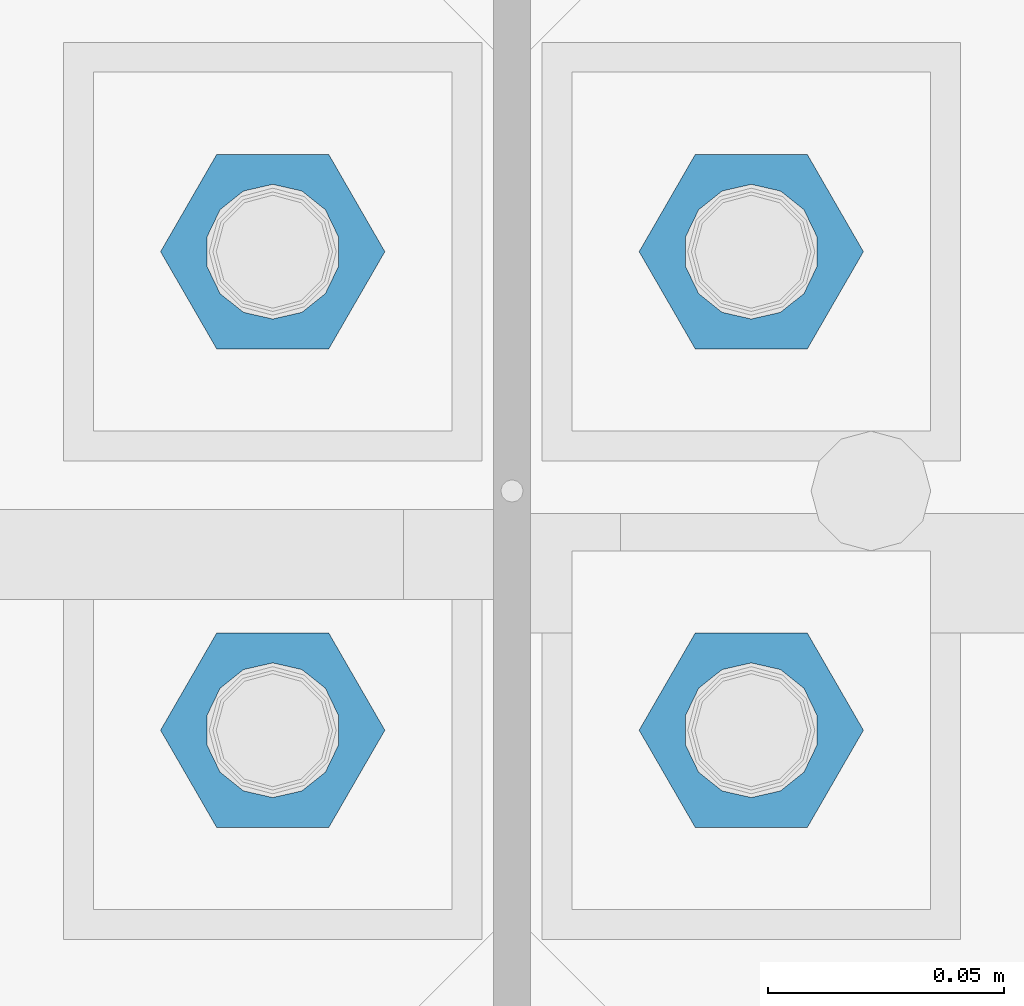
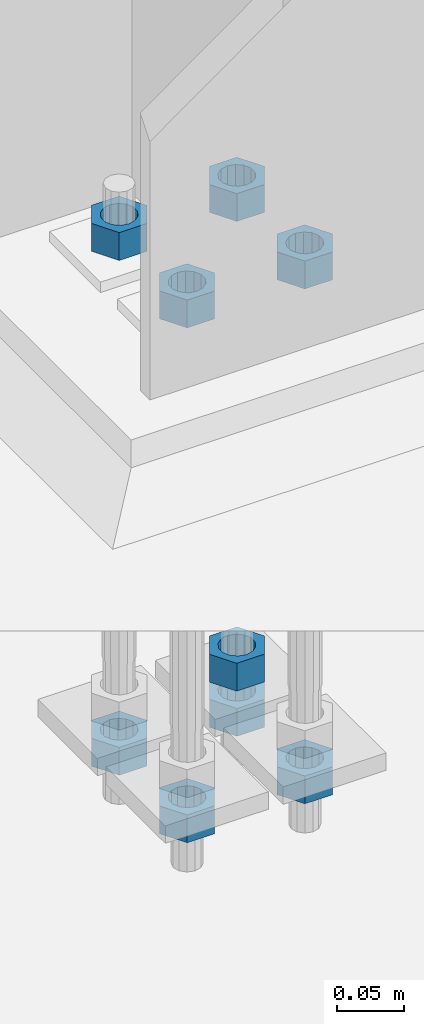
# One storey, part 1689 of 3843: 9 columns, 1 element without a shape of its own.
"""IFC2X3 building model written with IfcOpenShell, lengths in millimetres."""

from ifc_helpers import new_model, si_unit, frame, origin_with_axes, place, context, subcontext, project, spatial, faceted_brep, material, type_object, element, aggregate, save


model = new_model("IFC2X3")

# Units and contexts
model_context = context("Model", 3, precision=1e-05, world=origin_with_axes())
body_context = subcontext(model_context, "Body", "Model", "MODEL_VIEW")
ifc_project = project(units=[si_unit("LENGTHUNIT", "METRE", prefix="MILLI"), si_unit("AREAUNIT", "SQUARE_METRE"), si_unit("VOLUMEUNIT", "CUBIC_METRE"), si_unit("MASSUNIT", "GRAM", prefix="KILO"), si_unit("TIMEUNIT", "SECOND"), si_unit("PLANEANGLEUNIT", "RADIAN"), si_unit("SOLIDANGLEUNIT", "STERADIAN"), si_unit("THERMODYNAMICTEMPERATUREUNIT", "DEGREE_CELSIUS"), si_unit("LUMINOUSINTENSITYUNIT", "LUMEN")], contexts=[model_context])

# Site, building, storey
site_placement = place(None, origin_with_axes())
site = spatial("IfcSite", under=ifc_project, at=site_placement, CompositionType="ELEMENT")
building_placement = place(site_placement, origin_with_axes())
building = spatial("IfcBuilding", under=site, at=building_placement, Name="Undefined", CompositionType="ELEMENT")
storey_placement = place(building_placement, origin_with_axes())
storey = spatial("IfcBuildingStorey", under=building, at=storey_placement, Name="Undefined", CompositionType="ELEMENT", Elevation=0.0)

# Assembly, columns
assembly_placement = place(storey_placement, origin_with_axes())
assembly = element("IfcElementAssembly", 1, at=assembly_placement, inside=storey, Name="TEMPLATE", AssemblyPlace="NOTDEFINED", PredefinedType="RIGID_FRAME")
ifc_material = material(Name="STEEL/A36")
column_type = type_object("IfcColumnType", Name="1_HEAVY_HEX_NUT", PredefinedType="NOTDEFINED")
column_1_placement = place(assembly_placement, frame((7670.8, 104609.9, 29692.6), z_axis=(0.0, 1.0, 0.0), x_axis=(0.0, 0.0, -1.0)))
column_1 = element("IfcColumn", 2, at=column_1_placement, type_object=column_type, material=ifc_material, Name="NUT", ObjectType="1_HEAVY_HEX_NUT", context=body_context, shape_type="Brep", body=[
    faceted_brep([(0.0, -23.8099994659424, 0.0), (0.0, -11.9099998474121, -20.6200008392334), (25.3999999999978, -11.9099998474121, -20.6200008392334), (25.3999999999978, -23.8099994659424, 0.0), (0.0, 11.9099998474121, -20.6200008392334), (25.3999999999978, 11.9099998474121, -20.6200008392334), (0.0, 23.8099994659424, 0.0), (25.3999999999978, 23.8099994659424, 0.0), (0.0, 11.9099998474121, 20.6200008392334), (25.3999999999978, 11.9099998474121, 20.6200008392334), (0.0, -11.9099998474121, 20.6200008392334), (25.3999999999978, -11.9099998474121, 20.6200008392334), (0.0, 0.0, 14.289999961853), (0.0, 6.20019861543551, 12.8748450879575), (25.3999999999978, 6.20019861543551, 12.8748450879575), (25.3999999999978, 0.0, 14.289999961853), (0.0, 11.1723718546418, 8.90966924477834), (25.3999999999978, 11.1723718546418, 8.90966924477834), (0.0, 13.9317198278877, 3.17982413774735), (25.3999999999978, 13.9317198278877, 3.17982413774735), (0.0, 13.9317198278877, -3.17982413774735), (25.3999999999978, 13.9317198278877, -3.17982413774735), (0.0, 11.1723718546418, -8.90966924477834), (25.3999999999978, 11.1723718546418, -8.90966924477834), (0.0, 6.20019861543551, -12.8748450879575), (25.3999999999978, 6.20019861543551, -12.8748450879575), (0.0, 0.0, -14.289999961853), (25.3999999999978, 0.0, -14.289999961853), (0.0, -6.20019861543551, -12.8748450879575), (25.3999999999978, -6.20019861543551, -12.8748450879575), (0.0, -11.1723718546418, -8.90966924477834), (25.3999999999978, -11.1723718546418, -8.90966924477834), (0.0, -13.9317198278877, -3.17982413774735), (25.3999999999978, -13.9317198278877, -3.17982413774735), (0.0, -13.9317198278877, 3.17982413774735), (25.3999999999978, -13.9317198278877, 3.17982413774735), (0.0, -11.1723718546418, 8.90966924477834), (25.3999999999978, -11.1723718546418, 8.90966924477834), (0.0, -6.20019861543551, 12.8748450879575), (25.3999999999978, -6.20019861543551, 12.8748450879575)], [[[0, 1, 2, 3]], [[1, 4, 5, 2]], [[4, 6, 7, 5]], [[6, 8, 9, 7]], [[8, 10, 11, 9]], [[10, 0, 3, 11]], [[12, 13, 14, 15]], [[13, 16, 17, 14]], [[16, 18, 19, 17]], [[18, 20, 21, 19]], [[20, 22, 23, 21]], [[22, 24, 25, 23]], [[24, 26, 27, 25]], [[26, 28, 29, 27]], [[28, 30, 31, 29]], [[30, 32, 33, 31]], [[32, 34, 35, 33]], [[34, 36, 37, 35]], [[36, 38, 39, 37]], [[38, 12, 15, 39]], [[5, 7, 9, 11, 3, 2], [17, 19, 21, 23, 25, 27, 29, 31, 33, 35, 37, 39, 15, 14]], [[10, 8, 6, 4, 1, 0], [38, 36, 34, 32, 30, 28, 26, 24, 22, 20, 18, 16, 13, 12]]]),
])
column_2_placement = place(assembly_placement, frame((7569.2, 104508.3, 30121.225), z_axis=(0.0, -1.0, 0.0), x_axis=(0.0, 0.0, -1.0)))
column_2 = element("IfcColumn", 3, at=column_2_placement, type_object=column_type, material=ifc_material, Name="NUT", ObjectType="1_HEAVY_HEX_NUT", context=body_context, shape_type="Brep", body=[
    faceted_brep([(0.0, -23.8099994659424, 0.0), (0.0, -11.9099998474121, -20.6200008392334), (25.3999999999978, -11.9099998474121, -20.6200008392334), (25.3999999999978, -23.8099994659424, 0.0), (0.0, 11.9099998474121, -20.6200008392334), (25.3999999999978, 11.9099998474121, -20.6200008392334), (0.0, 23.8099994659424, 0.0), (25.3999999999978, 23.8099994659424, 0.0), (0.0, 11.9099998474121, 20.6200008392334), (25.3999999999978, 11.9099998474121, 20.6200008392334), (0.0, -11.9099998474121, 20.6200008392334), (25.3999999999978, -11.9099998474121, 20.6200008392334), (0.0, 0.0, 14.289999961853), (0.0, 6.20019861543551, 12.8748450879575), (25.3999999999978, 6.20019861543551, 12.8748450879575), (25.3999999999978, 0.0, 14.289999961853), (0.0, 11.1723718546418, 8.90966924477834), (25.3999999999978, 11.1723718546418, 8.90966924477834), (0.0, 13.9317198278877, 3.17982413774735), (25.3999999999978, 13.9317198278877, 3.17982413774735), (0.0, 13.9317198278877, -3.17982413774735), (25.3999999999978, 13.9317198278877, -3.17982413774735), (0.0, 11.1723718546418, -8.90966924477834), (25.3999999999978, 11.1723718546418, -8.90966924477834), (0.0, 6.20019861543551, -12.8748450879575), (25.3999999999978, 6.20019861543551, -12.8748450879575), (0.0, 0.0, -14.289999961853), (25.3999999999978, 0.0, -14.289999961853), (0.0, -6.20019861543551, -12.8748450879575), (25.3999999999978, -6.20019861543551, -12.8748450879575), (0.0, -11.1723718546418, -8.90966924477834), (25.3999999999978, -11.1723718546418, -8.90966924477834), (0.0, -13.9317198278877, -3.17982413774735), (25.3999999999978, -13.9317198278877, -3.17982413774735), (0.0, -13.9317198278877, 3.17982413774735), (25.3999999999978, -13.9317198278877, 3.17982413774735), (0.0, -11.1723718546418, 8.90966924477834), (25.3999999999978, -11.1723718546418, 8.90966924477834), (0.0, -6.20019861543551, 12.8748450879575), (25.3999999999978, -6.20019861543551, 12.8748450879575)], [[[0, 1, 2, 3]], [[1, 4, 5, 2]], [[4, 6, 7, 5]], [[6, 8, 9, 7]], [[8, 10, 11, 9]], [[10, 0, 3, 11]], [[12, 13, 14, 15]], [[13, 16, 17, 14]], [[16, 18, 19, 17]], [[18, 20, 21, 19]], [[20, 22, 23, 21]], [[22, 24, 25, 23]], [[24, 26, 27, 25]], [[26, 28, 29, 27]], [[28, 30, 31, 29]], [[30, 32, 33, 31]], [[32, 34, 35, 33]], [[34, 36, 37, 35]], [[36, 38, 39, 37]], [[38, 12, 15, 39]], [[5, 7, 9, 11, 3, 2], [17, 19, 21, 23, 25, 27, 29, 31, 33, 35, 37, 39, 15, 14]], [[10, 8, 6, 4, 1, 0], [38, 36, 34, 32, 30, 28, 26, 24, 22, 20, 18, 16, 13, 12]]]),
])
column_3_placement = place(assembly_placement, frame((7569.2, 104508.3, 29651.325), z_axis=(0.0, -1.0, 0.0), x_axis=(0.0, 0.0, -1.0)))
column_3 = element("IfcColumn", 4, at=column_3_placement, type_object=column_type, material=ifc_material, Name="NUT", ObjectType="1_HEAVY_HEX_NUT", context=body_context, shape_type="Brep", body=[
    faceted_brep([(0.0, -23.8099994659424, 0.0), (0.0, -11.9099998474121, -20.6200008392334), (25.3999999999978, -11.9099998474121, -20.6200008392334), (25.3999999999978, -23.8099994659424, 0.0), (0.0, 11.9099998474121, -20.6200008392334), (25.3999999999978, 11.9099998474121, -20.6200008392334), (0.0, 23.8099994659424, 0.0), (25.3999999999978, 23.8099994659424, 0.0), (0.0, 11.9099998474121, 20.6200008392334), (25.3999999999978, 11.9099998474121, 20.6200008392334), (0.0, -11.9099998474121, 20.6200008392334), (25.3999999999978, -11.9099998474121, 20.6200008392334), (0.0, 0.0, 14.289999961853), (0.0, 6.20019861543551, 12.8748450879575), (25.3999999999978, 6.20019861543551, 12.8748450879575), (25.3999999999978, 0.0, 14.289999961853), (0.0, 11.1723718546418, 8.90966924477834), (25.3999999999978, 11.1723718546418, 8.90966924477834), (0.0, 13.9317198278877, 3.17982413774735), (25.3999999999978, 13.9317198278877, 3.17982413774735), (0.0, 13.9317198278877, -3.17982413774735), (25.3999999999978, 13.9317198278877, -3.17982413774735), (0.0, 11.1723718546418, -8.90966924477834), (25.3999999999978, 11.1723718546418, -8.90966924477834), (0.0, 6.20019861543551, -12.8748450879575), (25.3999999999978, 6.20019861543551, -12.8748450879575), (0.0, 0.0, -14.289999961853), (25.3999999999978, 0.0, -14.289999961853), (0.0, -6.20019861543551, -12.8748450879575), (25.3999999999978, -6.20019861543551, -12.8748450879575), (0.0, -11.1723718546418, -8.90966924477834), (25.3999999999978, -11.1723718546418, -8.90966924477834), (0.0, -13.9317198278877, -3.17982413774735), (25.3999999999978, -13.9317198278877, -3.17982413774735), (0.0, -13.9317198278877, 3.17982413774735), (25.3999999999978, -13.9317198278877, 3.17982413774735), (0.0, -11.1723718546418, 8.90966924477834), (25.3999999999978, -11.1723718546418, 8.90966924477834), (0.0, -6.20019861543551, 12.8748450879575), (25.3999999999978, -6.20019861543551, 12.8748450879575)], [[[0, 1, 2, 3]], [[1, 4, 5, 2]], [[4, 6, 7, 5]], [[6, 8, 9, 7]], [[8, 10, 11, 9]], [[10, 0, 3, 11]], [[12, 13, 14, 15]], [[13, 16, 17, 14]], [[16, 18, 19, 17]], [[18, 20, 21, 19]], [[20, 22, 23, 21]], [[22, 24, 25, 23]], [[24, 26, 27, 25]], [[26, 28, 29, 27]], [[28, 30, 31, 29]], [[30, 32, 33, 31]], [[32, 34, 35, 33]], [[34, 36, 37, 35]], [[36, 38, 39, 37]], [[38, 12, 15, 39]], [[5, 7, 9, 11, 3, 2], [17, 19, 21, 23, 25, 27, 29, 31, 33, 35, 37, 39, 15, 14]], [[10, 8, 6, 4, 1, 0], [38, 36, 34, 32, 30, 28, 26, 24, 22, 20, 18, 16, 13, 12]]]),
])
column_4_placement = place(assembly_placement, frame((7670.8, 104508.3, 30121.225), z_axis=(0.0, 1.0, 0.0), x_axis=(0.0, 0.0, -1.0)))
column_4 = element("IfcColumn", 5, at=column_4_placement, type_object=column_type, material=ifc_material, Name="NUT", ObjectType="1_HEAVY_HEX_NUT", context=body_context, shape_type="Brep", body=[
    faceted_brep([(0.0, -23.8099994659424, 0.0), (0.0, -11.9099998474121, -20.6200008392334), (25.3999999999978, -11.9099998474121, -20.6200008392334), (25.3999999999978, -23.8099994659424, 0.0), (0.0, 11.9099998474121, -20.6200008392334), (25.3999999999978, 11.9099998474121, -20.6200008392334), (0.0, 23.8099994659424, 0.0), (25.3999999999978, 23.8099994659424, 0.0), (0.0, 11.9099998474121, 20.6200008392334), (25.3999999999978, 11.9099998474121, 20.6200008392334), (0.0, -11.9099998474121, 20.6200008392334), (25.3999999999978, -11.9099998474121, 20.6200008392334), (0.0, 0.0, 14.289999961853), (0.0, 6.20019861543551, 12.8748450879575), (25.3999999999978, 6.20019861543551, 12.8748450879575), (25.3999999999978, 0.0, 14.289999961853), (0.0, 11.1723718546418, 8.90966924477834), (25.3999999999978, 11.1723718546418, 8.90966924477834), (0.0, 13.9317198278877, 3.17982413774735), (25.3999999999978, 13.9317198278877, 3.17982413774735), (0.0, 13.9317198278877, -3.17982413774735), (25.3999999999978, 13.9317198278877, -3.17982413774735), (0.0, 11.1723718546418, -8.90966924477834), (25.3999999999978, 11.1723718546418, -8.90966924477834), (0.0, 6.20019861543551, -12.8748450879575), (25.3999999999978, 6.20019861543551, -12.8748450879575), (0.0, 0.0, -14.289999961853), (25.3999999999978, 0.0, -14.289999961853), (0.0, -6.20019861543551, -12.8748450879575), (25.3999999999978, -6.20019861543551, -12.8748450879575), (0.0, -11.1723718546418, -8.90966924477834), (25.3999999999978, -11.1723718546418, -8.90966924477834), (0.0, -13.9317198278877, -3.17982413774735), (25.3999999999978, -13.9317198278877, -3.17982413774735), (0.0, -13.9317198278877, 3.17982413774735), (25.3999999999978, -13.9317198278877, 3.17982413774735), (0.0, -11.1723718546418, 8.90966924477834), (25.3999999999978, -11.1723718546418, 8.90966924477834), (0.0, -6.20019861543551, 12.8748450879575), (25.3999999999978, -6.20019861543551, 12.8748450879575)], [[[0, 1, 2, 3]], [[1, 4, 5, 2]], [[4, 6, 7, 5]], [[6, 8, 9, 7]], [[8, 10, 11, 9]], [[10, 0, 3, 11]], [[12, 13, 14, 15]], [[13, 16, 17, 14]], [[16, 18, 19, 17]], [[18, 20, 21, 19]], [[20, 22, 23, 21]], [[22, 24, 25, 23]], [[24, 26, 27, 25]], [[26, 28, 29, 27]], [[28, 30, 31, 29]], [[30, 32, 33, 31]], [[32, 34, 35, 33]], [[34, 36, 37, 35]], [[36, 38, 39, 37]], [[38, 12, 15, 39]], [[5, 7, 9, 11, 3, 2], [17, 19, 21, 23, 25, 27, 29, 31, 33, 35, 37, 39, 15, 14]], [[10, 8, 6, 4, 1, 0], [38, 36, 34, 32, 30, 28, 26, 24, 22, 20, 18, 16, 13, 12]]]),
])
column_5_placement = place(assembly_placement, frame((7670.8, 104508.3, 29651.325), z_axis=(0.0, 1.0, 0.0), x_axis=(0.0, 0.0, -1.0)))
column_5 = element("IfcColumn", 6, at=column_5_placement, type_object=column_type, material=ifc_material, Name="NUT", ObjectType="1_HEAVY_HEX_NUT", context=body_context, shape_type="Brep", body=[
    faceted_brep([(0.0, -23.8099994659424, 0.0), (0.0, -11.9099998474121, -20.6200008392334), (25.3999999999978, -11.9099998474121, -20.6200008392334), (25.3999999999978, -23.8099994659424, 0.0), (0.0, 11.9099998474121, -20.6200008392334), (25.3999999999978, 11.9099998474121, -20.6200008392334), (0.0, 23.8099994659424, 0.0), (25.3999999999978, 23.8099994659424, 0.0), (0.0, 11.9099998474121, 20.6200008392334), (25.3999999999978, 11.9099998474121, 20.6200008392334), (0.0, -11.9099998474121, 20.6200008392334), (25.3999999999978, -11.9099998474121, 20.6200008392334), (0.0, 0.0, 14.289999961853), (0.0, 6.20019861543551, 12.8748450879575), (25.3999999999978, 6.20019861543551, 12.8748450879575), (25.3999999999978, 0.0, 14.289999961853), (0.0, 11.1723718546418, 8.90966924477834), (25.3999999999978, 11.1723718546418, 8.90966924477834), (0.0, 13.9317198278877, 3.17982413774735), (25.3999999999978, 13.9317198278877, 3.17982413774735), (0.0, 13.9317198278877, -3.17982413774735), (25.3999999999978, 13.9317198278877, -3.17982413774735), (0.0, 11.1723718546418, -8.90966924477834), (25.3999999999978, 11.1723718546418, -8.90966924477834), (0.0, 6.20019861543551, -12.8748450879575), (25.3999999999978, 6.20019861543551, -12.8748450879575), (0.0, 0.0, -14.289999961853), (25.3999999999978, 0.0, -14.289999961853), (0.0, -6.20019861543551, -12.8748450879575), (25.3999999999978, -6.20019861543551, -12.8748450879575), (0.0, -11.1723718546418, -8.90966924477834), (25.3999999999978, -11.1723718546418, -8.90966924477834), (0.0, -13.9317198278877, -3.17982413774735), (25.3999999999978, -13.9317198278877, -3.17982413774735), (0.0, -13.9317198278877, 3.17982413774735), (25.3999999999978, -13.9317198278877, 3.17982413774735), (0.0, -11.1723718546418, 8.90966924477834), (25.3999999999978, -11.1723718546418, 8.90966924477834), (0.0, -6.20019861543551, 12.8748450879575), (25.3999999999978, -6.20019861543551, 12.8748450879575)], [[[0, 1, 2, 3]], [[1, 4, 5, 2]], [[4, 6, 7, 5]], [[6, 8, 9, 7]], [[8, 10, 11, 9]], [[10, 0, 3, 11]], [[12, 13, 14, 15]], [[13, 16, 17, 14]], [[16, 18, 19, 17]], [[18, 20, 21, 19]], [[20, 22, 23, 21]], [[22, 24, 25, 23]], [[24, 26, 27, 25]], [[26, 28, 29, 27]], [[28, 30, 31, 29]], [[30, 32, 33, 31]], [[32, 34, 35, 33]], [[34, 36, 37, 35]], [[36, 38, 39, 37]], [[38, 12, 15, 39]], [[5, 7, 9, 11, 3, 2], [17, 19, 21, 23, 25, 27, 29, 31, 33, 35, 37, 39, 15, 14]], [[10, 8, 6, 4, 1, 0], [38, 36, 34, 32, 30, 28, 26, 24, 22, 20, 18, 16, 13, 12]]]),
])
column_6_placement = place(assembly_placement, frame((7569.2, 104609.9, 30121.225), z_axis=(0.0, -1.0, 0.0), x_axis=(0.0, 0.0, -1.0)))
column_6 = element("IfcColumn", 7, at=column_6_placement, type_object=column_type, material=ifc_material, Name="NUT", ObjectType="1_HEAVY_HEX_NUT", context=body_context, shape_type="Brep", body=[
    faceted_brep([(0.0, -23.8099994659424, 0.0), (0.0, -11.9099998474121, -20.6200008392334), (25.3999999999978, -11.9099998474121, -20.6200008392334), (25.3999999999978, -23.8099994659424, 0.0), (0.0, 11.9099998474121, -20.6200008392334), (25.3999999999978, 11.9099998474121, -20.6200008392334), (0.0, 23.8099994659424, 0.0), (25.3999999999978, 23.8099994659424, 0.0), (0.0, 11.9099998474121, 20.6200008392334), (25.3999999999978, 11.9099998474121, 20.6200008392334), (0.0, -11.9099998474121, 20.6200008392334), (25.3999999999978, -11.9099998474121, 20.6200008392334), (0.0, 0.0, 14.289999961853), (0.0, 6.20019861543551, 12.8748450879575), (25.3999999999978, 6.20019861543551, 12.8748450879575), (25.3999999999978, 0.0, 14.289999961853), (0.0, 11.1723718546418, 8.90966924477834), (25.3999999999978, 11.1723718546418, 8.90966924477834), (0.0, 13.9317198278877, 3.17982413774735), (25.3999999999978, 13.9317198278877, 3.17982413774735), (0.0, 13.9317198278877, -3.17982413774735), (25.3999999999978, 13.9317198278877, -3.17982413774735), (0.0, 11.1723718546418, -8.90966924477834), (25.3999999999978, 11.1723718546418, -8.90966924477834), (0.0, 6.20019861543551, -12.8748450879575), (25.3999999999978, 6.20019861543551, -12.8748450879575), (0.0, 0.0, -14.289999961853), (25.3999999999978, 0.0, -14.289999961853), (0.0, -6.20019861543551, -12.8748450879575), (25.3999999999978, -6.20019861543551, -12.8748450879575), (0.0, -11.1723718546418, -8.90966924477834), (25.3999999999978, -11.1723718546418, -8.90966924477834), (0.0, -13.9317198278877, -3.17982413774735), (25.3999999999978, -13.9317198278877, -3.17982413774735), (0.0, -13.9317198278877, 3.17982413774735), (25.3999999999978, -13.9317198278877, 3.17982413774735), (0.0, -11.1723718546418, 8.90966924477834), (25.3999999999978, -11.1723718546418, 8.90966924477834), (0.0, -6.20019861543551, 12.8748450879575), (25.3999999999978, -6.20019861543551, 12.8748450879575)], [[[0, 1, 2, 3]], [[1, 4, 5, 2]], [[4, 6, 7, 5]], [[6, 8, 9, 7]], [[8, 10, 11, 9]], [[10, 0, 3, 11]], [[12, 13, 14, 15]], [[13, 16, 17, 14]], [[16, 18, 19, 17]], [[18, 20, 21, 19]], [[20, 22, 23, 21]], [[22, 24, 25, 23]], [[24, 26, 27, 25]], [[26, 28, 29, 27]], [[28, 30, 31, 29]], [[30, 32, 33, 31]], [[32, 34, 35, 33]], [[34, 36, 37, 35]], [[36, 38, 39, 37]], [[38, 12, 15, 39]], [[5, 7, 9, 11, 3, 2], [17, 19, 21, 23, 25, 27, 29, 31, 33, 35, 37, 39, 15, 14]], [[10, 8, 6, 4, 1, 0], [38, 36, 34, 32, 30, 28, 26, 24, 22, 20, 18, 16, 13, 12]]]),
])
column_7_placement = place(assembly_placement, frame((7569.2, 104609.9, 29651.325), z_axis=(0.0, -1.0, 0.0), x_axis=(0.0, 0.0, -1.0)))
column_7 = element("IfcColumn", 8, at=column_7_placement, type_object=column_type, material=ifc_material, Name="NUT", ObjectType="1_HEAVY_HEX_NUT", context=body_context, shape_type="Brep", body=[
    faceted_brep([(0.0, -23.8099994659424, 0.0), (0.0, -11.9099998474121, -20.6200008392334), (25.3999999999978, -11.9099998474121, -20.6200008392334), (25.3999999999978, -23.8099994659424, 0.0), (0.0, 11.9099998474121, -20.6200008392334), (25.3999999999978, 11.9099998474121, -20.6200008392334), (0.0, 23.8099994659424, 0.0), (25.3999999999978, 23.8099994659424, 0.0), (0.0, 11.9099998474121, 20.6200008392334), (25.3999999999978, 11.9099998474121, 20.6200008392334), (0.0, -11.9099998474121, 20.6200008392334), (25.3999999999978, -11.9099998474121, 20.6200008392334), (0.0, 0.0, 14.289999961853), (0.0, 6.20019861543551, 12.8748450879575), (25.3999999999978, 6.20019861543551, 12.8748450879575), (25.3999999999978, 0.0, 14.289999961853), (0.0, 11.1723718546418, 8.90966924477834), (25.3999999999978, 11.1723718546418, 8.90966924477834), (0.0, 13.9317198278877, 3.17982413774735), (25.3999999999978, 13.9317198278877, 3.17982413774735), (0.0, 13.9317198278877, -3.17982413774735), (25.3999999999978, 13.9317198278877, -3.17982413774735), (0.0, 11.1723718546418, -8.90966924477834), (25.3999999999978, 11.1723718546418, -8.90966924477834), (0.0, 6.20019861543551, -12.8748450879575), (25.3999999999978, 6.20019861543551, -12.8748450879575), (0.0, 0.0, -14.289999961853), (25.3999999999978, 0.0, -14.289999961853), (0.0, -6.20019861543551, -12.8748450879575), (25.3999999999978, -6.20019861543551, -12.8748450879575), (0.0, -11.1723718546418, -8.90966924477834), (25.3999999999978, -11.1723718546418, -8.90966924477834), (0.0, -13.9317198278877, -3.17982413774735), (25.3999999999978, -13.9317198278877, -3.17982413774735), (0.0, -13.9317198278877, 3.17982413774735), (25.3999999999978, -13.9317198278877, 3.17982413774735), (0.0, -11.1723718546418, 8.90966924477834), (25.3999999999978, -11.1723718546418, 8.90966924477834), (0.0, -6.20019861543551, 12.8748450879575), (25.3999999999978, -6.20019861543551, 12.8748450879575)], [[[0, 1, 2, 3]], [[1, 4, 5, 2]], [[4, 6, 7, 5]], [[6, 8, 9, 7]], [[8, 10, 11, 9]], [[10, 0, 3, 11]], [[12, 13, 14, 15]], [[13, 16, 17, 14]], [[16, 18, 19, 17]], [[18, 20, 21, 19]], [[20, 22, 23, 21]], [[22, 24, 25, 23]], [[24, 26, 27, 25]], [[26, 28, 29, 27]], [[28, 30, 31, 29]], [[30, 32, 33, 31]], [[32, 34, 35, 33]], [[34, 36, 37, 35]], [[36, 38, 39, 37]], [[38, 12, 15, 39]], [[5, 7, 9, 11, 3, 2], [17, 19, 21, 23, 25, 27, 29, 31, 33, 35, 37, 39, 15, 14]], [[10, 8, 6, 4, 1, 0], [38, 36, 34, 32, 30, 28, 26, 24, 22, 20, 18, 16, 13, 12]]]),
])
column_8_placement = place(assembly_placement, frame((7670.8, 104609.9, 30121.225), z_axis=(0.0, 1.0, 0.0), x_axis=(0.0, 0.0, -1.0)))
column_8 = element("IfcColumn", 9, at=column_8_placement, type_object=column_type, material=ifc_material, Name="NUT", ObjectType="1_HEAVY_HEX_NUT", context=body_context, shape_type="Brep", body=[
    faceted_brep([(0.0, -23.8099994659424, 0.0), (0.0, -11.9099998474121, -20.6200008392334), (25.3999999999978, -11.9099998474121, -20.6200008392334), (25.3999999999978, -23.8099994659424, 0.0), (0.0, 11.9099998474121, -20.6200008392334), (25.3999999999978, 11.9099998474121, -20.6200008392334), (0.0, 23.8099994659424, 0.0), (25.3999999999978, 23.8099994659424, 0.0), (0.0, 11.9099998474121, 20.6200008392334), (25.3999999999978, 11.9099998474121, 20.6200008392334), (0.0, -11.9099998474121, 20.6200008392334), (25.3999999999978, -11.9099998474121, 20.6200008392334), (0.0, 0.0, 14.289999961853), (0.0, 6.20019861543551, 12.8748450879575), (25.3999999999978, 6.20019861543551, 12.8748450879575), (25.3999999999978, 0.0, 14.289999961853), (0.0, 11.1723718546418, 8.90966924477834), (25.3999999999978, 11.1723718546418, 8.90966924477834), (0.0, 13.9317198278877, 3.17982413774735), (25.3999999999978, 13.9317198278877, 3.17982413774735), (0.0, 13.9317198278877, -3.17982413774735), (25.3999999999978, 13.9317198278877, -3.17982413774735), (0.0, 11.1723718546418, -8.90966924477834), (25.3999999999978, 11.1723718546418, -8.90966924477834), (0.0, 6.20019861543551, -12.8748450879575), (25.3999999999978, 6.20019861543551, -12.8748450879575), (0.0, 0.0, -14.289999961853), (25.3999999999978, 0.0, -14.289999961853), (0.0, -6.20019861543551, -12.8748450879575), (25.3999999999978, -6.20019861543551, -12.8748450879575), (0.0, -11.1723718546418, -8.90966924477834), (25.3999999999978, -11.1723718546418, -8.90966924477834), (0.0, -13.9317198278877, -3.17982413774735), (25.3999999999978, -13.9317198278877, -3.17982413774735), (0.0, -13.9317198278877, 3.17982413774735), (25.3999999999978, -13.9317198278877, 3.17982413774735), (0.0, -11.1723718546418, 8.90966924477834), (25.3999999999978, -11.1723718546418, 8.90966924477834), (0.0, -6.20019861543551, 12.8748450879575), (25.3999999999978, -6.20019861543551, 12.8748450879575)], [[[0, 1, 2, 3]], [[1, 4, 5, 2]], [[4, 6, 7, 5]], [[6, 8, 9, 7]], [[8, 10, 11, 9]], [[10, 0, 3, 11]], [[12, 13, 14, 15]], [[13, 16, 17, 14]], [[16, 18, 19, 17]], [[18, 20, 21, 19]], [[20, 22, 23, 21]], [[22, 24, 25, 23]], [[24, 26, 27, 25]], [[26, 28, 29, 27]], [[28, 30, 31, 29]], [[30, 32, 33, 31]], [[32, 34, 35, 33]], [[34, 36, 37, 35]], [[36, 38, 39, 37]], [[38, 12, 15, 39]], [[5, 7, 9, 11, 3, 2], [17, 19, 21, 23, 25, 27, 29, 31, 33, 35, 37, 39, 15, 14]], [[10, 8, 6, 4, 1, 0], [38, 36, 34, 32, 30, 28, 26, 24, 22, 20, 18, 16, 13, 12]]]),
])
column_9_placement = place(assembly_placement, frame((7670.8, 104609.9, 29651.325), z_axis=(0.0, 1.0, 0.0), x_axis=(0.0, 0.0, -1.0)))
column_9 = element("IfcColumn", 10, at=column_9_placement, type_object=column_type, material=ifc_material, Name="NUT", ObjectType="1_HEAVY_HEX_NUT", context=body_context, shape_type="Brep", body=[
    faceted_brep([(0.0, -23.8099994659424, 0.0), (0.0, -11.9099998474121, -20.6200008392334), (25.3999999999978, -11.9099998474121, -20.6200008392334), (25.3999999999978, -23.8099994659424, 0.0), (0.0, 11.9099998474121, -20.6200008392334), (25.3999999999978, 11.9099998474121, -20.6200008392334), (0.0, 23.8099994659424, 0.0), (25.3999999999978, 23.8099994659424, 0.0), (0.0, 11.9099998474121, 20.6200008392334), (25.3999999999978, 11.9099998474121, 20.6200008392334), (0.0, -11.9099998474121, 20.6200008392334), (25.3999999999978, -11.9099998474121, 20.6200008392334), (0.0, 0.0, 14.289999961853), (0.0, 6.20019861543551, 12.8748450879575), (25.3999999999978, 6.20019861543551, 12.8748450879575), (25.3999999999978, 0.0, 14.289999961853), (0.0, 11.1723718546418, 8.90966924477834), (25.3999999999978, 11.1723718546418, 8.90966924477834), (0.0, 13.9317198278877, 3.17982413774735), (25.3999999999978, 13.9317198278877, 3.17982413774735), (0.0, 13.9317198278877, -3.17982413774735), (25.3999999999978, 13.9317198278877, -3.17982413774735), (0.0, 11.1723718546418, -8.90966924477834), (25.3999999999978, 11.1723718546418, -8.90966924477834), (0.0, 6.20019861543551, -12.8748450879575), (25.3999999999978, 6.20019861543551, -12.8748450879575), (0.0, 0.0, -14.289999961853), (25.3999999999978, 0.0, -14.289999961853), (0.0, -6.20019861543551, -12.8748450879575), (25.3999999999978, -6.20019861543551, -12.8748450879575), (0.0, -11.1723718546418, -8.90966924477834), (25.3999999999978, -11.1723718546418, -8.90966924477834), (0.0, -13.9317198278877, -3.17982413774735), (25.3999999999978, -13.9317198278877, -3.17982413774735), (0.0, -13.9317198278877, 3.17982413774735), (25.3999999999978, -13.9317198278877, 3.17982413774735), (0.0, -11.1723718546418, 8.90966924477834), (25.3999999999978, -11.1723718546418, 8.90966924477834), (0.0, -6.20019861543551, 12.8748450879575), (25.3999999999978, -6.20019861543551, 12.8748450879575)], [[[0, 1, 2, 3]], [[1, 4, 5, 2]], [[4, 6, 7, 5]], [[6, 8, 9, 7]], [[8, 10, 11, 9]], [[10, 0, 3, 11]], [[12, 13, 14, 15]], [[13, 16, 17, 14]], [[16, 18, 19, 17]], [[18, 20, 21, 19]], [[20, 22, 23, 21]], [[22, 24, 25, 23]], [[24, 26, 27, 25]], [[26, 28, 29, 27]], [[28, 30, 31, 29]], [[30, 32, 33, 31]], [[32, 34, 35, 33]], [[34, 36, 37, 35]], [[36, 38, 39, 37]], [[38, 12, 15, 39]], [[5, 7, 9, 11, 3, 2], [17, 19, 21, 23, 25, 27, 29, 31, 33, 35, 37, 39, 15, 14]], [[10, 8, 6, 4, 1, 0], [38, 36, 34, 32, 30, 28, 26, 24, 22, 20, 18, 16, 13, 12]]]),
])
aggregate(assembly, [column_1, column_2, column_3, column_4, column_5, column_6, column_7, column_8, column_9])

save(model, "model.ifc")
